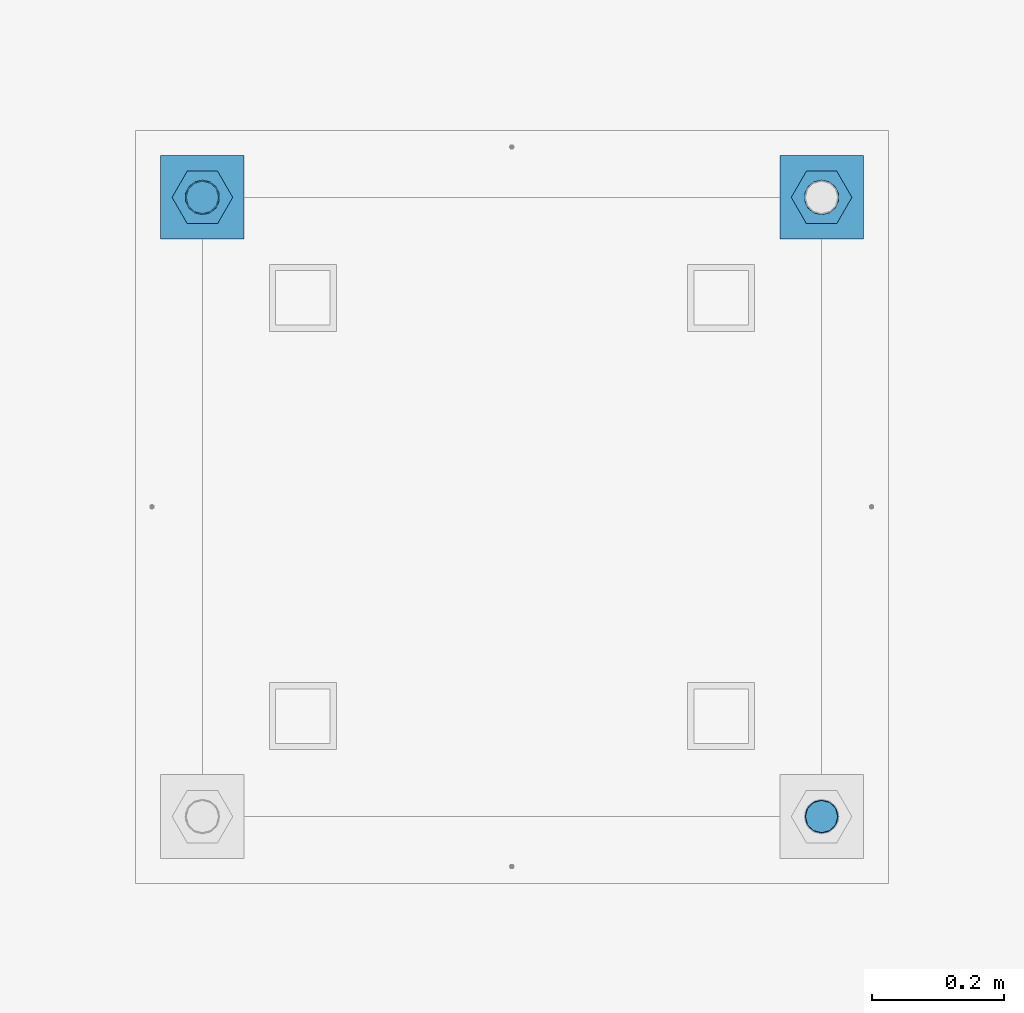
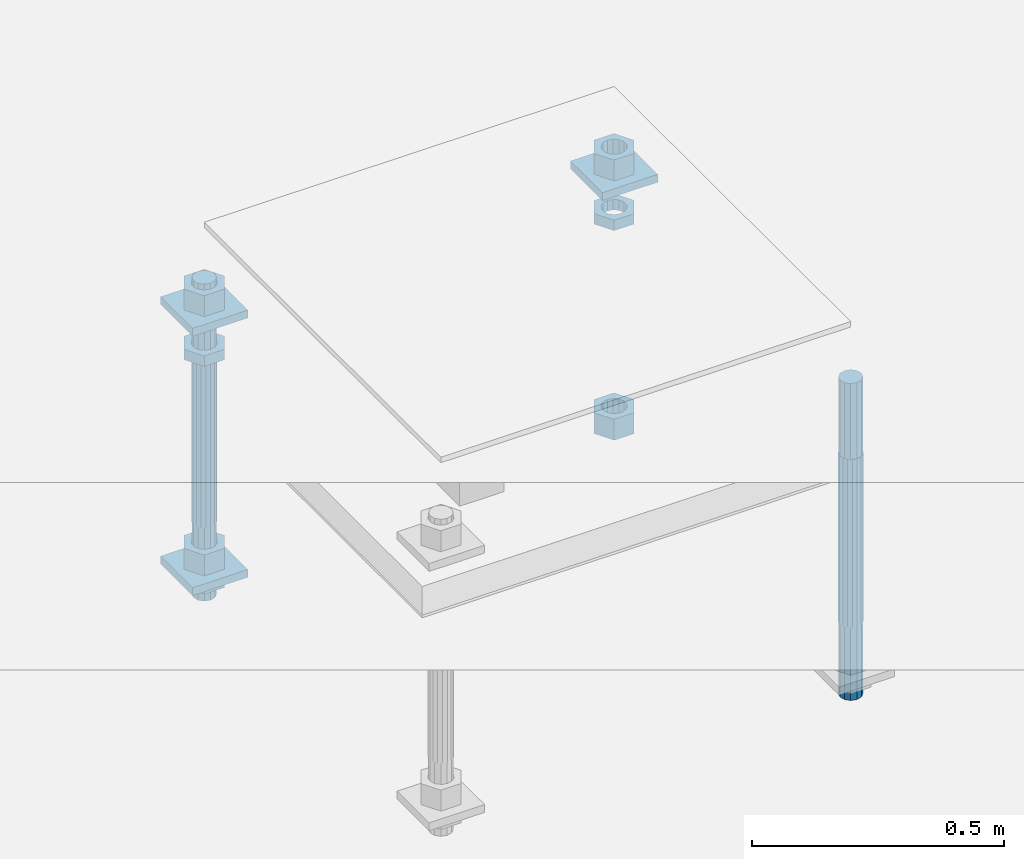
# One storey, part 2578 of 3843: 12 beams, 1 element without a shape of its own.
"""IFC2X3 building model written with IfcOpenShell, lengths in millimetres."""

import ifcopenshell
import ifcopenshell.guid

model = None  # the IFC model being written
_history = None  # IfcOwnerHistory: only IFC2X3 demands one
_inside = {}  # id of a spatial element -> (the spatial element, [elements in it])
_under = {}  # id of a project, library or spatial element -> (it, [spatial elements below it])
_declared = {}  # id of a project -> (the project, [libraries it declares])
_typed = {}  # id of a type object -> (the type object, [elements of that type])
_made_of = {}  # id of a material, layer set ... -> (it, [elements and type objects made of it])


def new_model(schema):
    """Start an empty IFC model of exactly this schema.

    Asked for "IFC4X3", IfcOpenShell would pick the latest addendum, in which some entities
    have other attributes; the version numbers below select the first issue.
    IFC2X3 requires an IfcOwnerHistory on every rooted entity: one is made here for all.
    """
    global model, _history
    if schema == "IFC4X3":
        model = ifcopenshell.file(schema_version=(4, 3, 0, 0))
    else:
        model = ifcopenshell.file(schema=schema)
    _inside.clear()
    _under.clear()
    _declared.clear()
    _typed.clear()
    _made_of.clear()
    _history = None
    if model.schema == "IFC2X3":
        org = make("IfcOrganization", Name="unknown")
        user = make(
            "IfcPersonAndOrganization",
            ThePerson=make("IfcPerson", FamilyName="unknown"),
            TheOrganization=org,
        )
        app = make(
            "IfcApplication",
            ApplicationDeveloper=org,
            Version="unknown",
            ApplicationFullName="unknown",
            ApplicationIdentifier="unknown",
        )
        _history = make(
            "IfcOwnerHistory",
            OwningUser=user,
            OwningApplication=app,
            ChangeAction="ADDED",
            CreationDate=0,
        )
    return model


def make(cls, **values):
    """One entity of the class cls with the attributes given. An attribute that is None is left unset."""
    return model.create_entity(
        cls, **{name: value for name, value in values.items() if value is not None}
    )


def rooted(cls, **values):
    """An entity with a GlobalId (a new one), such as an element, a storey or a relation."""
    return make(cls, GlobalId=ifcopenshell.guid.new(), OwnerHistory=_history, **values)


def si_unit(unit_type, name, prefix=None):
    """IfcSIUnit, for example si_unit("LENGTHUNIT", "METRE", prefix="MILLI")."""
    return make("IfcSIUnit", UnitType=unit_type, Prefix=prefix, Name=name)


def assignment(units):
    """IfcUnitAssignment: the units of a project."""
    return None if units is None else make("IfcUnitAssignment", Units=units)


def point(xyz):
    """IfcCartesianPoint."""
    return None if xyz is None else make("IfcCartesianPoint", Coordinates=xyz)


def direction(xyz):
    """IfcDirection."""
    return None if xyz is None else make("IfcDirection", DirectionRatios=xyz)


def frame(location, z_axis=None, x_axis=None):
    """IfcAxis2Placement3D, a coordinate frame: its origin and axes. An axis left out is left unset."""
    return make(
        "IfcAxis2Placement3D",
        Location=point(location),
        Axis=direction(z_axis),
        RefDirection=direction(x_axis),
    )


def origin_with_axes():
    """The frame at (0, 0, 0) with the z axis (0, 0, 1) and the x axis (1, 0, 0) written out."""
    return frame((0.0, 0.0, 0.0), z_axis=(0.0, 0.0, 1.0), x_axis=(1.0, 0.0, 0.0))


def place(relative_to, where):
    """IfcLocalPlacement: puts the frame where relative to a parent placement (None: the world)."""
    return make(
        "IfcLocalPlacement", PlacementRelTo=relative_to, RelativePlacement=where
    )


def context(
    kind, dimensions, precision=None, world=None, true_north=None, identifier=None
):
    """IfcGeometricRepresentationContext, for example the 3D "Model" context."""
    return make(
        "IfcGeometricRepresentationContext",
        ContextIdentifier=identifier,
        ContextType=kind,
        CoordinateSpaceDimension=dimensions,
        Precision=precision,
        WorldCoordinateSystem=world,
        TrueNorth=true_north,
    )


def subcontext(parent, identifier, kind, view, scale=None):
    """IfcGeometricRepresentationSubContext, for example "Body" below "Model"."""
    return make(
        "IfcGeometricRepresentationSubContext",
        ContextIdentifier=identifier,
        ContextType=kind,
        ParentContext=parent,
        TargetScale=scale,
        TargetView=view,
    )


def project(units=None, contexts=None):
    """IfcProject with its units and contexts."""
    return rooted(
        "IfcProject",
        Name="project",
        RepresentationContexts=contexts,
        UnitsInContext=assignment(units),
    )


def spatial(cls, under=None, at=None, **own):
    """A site, building, storey or space (cls), placed at a placement, below another one or the project."""
    s = rooted(cls, ObjectPlacement=at, **own)
    if under is not None:
        _under.setdefault(under.id(), (under, []))[1].append(s)
    return s


def faces_of(points, faces, orient=None, outer=None):
    """IfcFace entities. A face is a list of loops; a loop is a list of indices into points, from 0.

    orient and outer hold one flag for each loop. By default every Orientation is true, the
    first loop of a face is its IfcFaceOuterBound and the others are IfcFaceBound.
    """
    made = []
    for i, loops in enumerate(faces):
        bounds = []
        for j, loop in enumerate(loops):
            is_outer = j == 0 if outer is None else outer[i][j]
            bounds.append(
                make(
                    "IfcFaceOuterBound" if is_outer else "IfcFaceBound",
                    Bound=make("IfcPolyLoop", Polygon=[points[k] for k in loop]),
                    Orientation=True if orient is None else orient[i][j],
                )
            )
        made.append(make("IfcFace", Bounds=bounds))
    return made


def faceted_brep(points, faces, orient=None, outer=None, voids=None):
    """IfcFacetedBrep: a solid bounded by flat faces; with voids (closed shells), ...WithVoids."""
    shared = [point(p) for p in points]
    hull = make("IfcClosedShell", CfsFaces=faces_of(shared, faces, orient, outer))
    if voids is None:
        return make("IfcFacetedBrep", Outer=hull)
    return make(
        "IfcFacetedBrepWithVoids",
        Outer=hull,
        Voids=[
            make(cls, CfsFaces=faces_of(shared, fs, o, b)) for cls, fs, o, b in voids
        ],
    )


def shape(context_of_items, identifier, shape_type, items):
    """IfcShapeRepresentation: the items that make up one representation, for example the "Body"."""
    return make(
        "IfcShapeRepresentation",
        ContextOfItems=context_of_items,
        RepresentationIdentifier=identifier,
        RepresentationType=shape_type,
        Items=items,
    )


def material(Name=None, Category=None):
    """IfcMaterial."""
    return make("IfcMaterial", Name=Name, Category=Category)


def made_of(thing, what):
    """Note that an element or type object is made of a material, layer set ...; save() writes the relation."""
    if what is not None:
        _made_of.setdefault(what.id(), (what, []))[1].append(thing)
    return thing


def type_object(cls, material=None, **own):
    """A type object (cls), such as IfcWallType, which elements share."""
    return made_of(rooted(cls, **own), material)


def element(
    cls,
    number,
    at=None,
    inside=None,
    cuts=None,
    type_object=None,
    material=None,
    context=None,
    identifier="Body",
    shape_type=None,
    held_by="IfcProductDefinitionShape",
    body=None,
    shapes=None,
    **own,
):
    """One element of the class cls, such as IfcWall. Its Tag is "e" and its number.

    at: its placement. inside: the storey or other place that contains it. cuts: it is an
    opening in that element (IfcRelVoidsElement). A single representation is given by context,
    identifier, shape_type and body (its items); several are given by shapes. held_by: the class
    of the entity that holds the representations. save() writes the other relations.
    """
    e = rooted(cls, Tag="e%d" % number, ObjectPlacement=at, **own)
    if body is not None:
        shapes = [shape(context, identifier, shape_type, body)]
    if shapes is not None:
        e.Representation = make(held_by, Representations=shapes)
    if inside is not None:
        _inside.setdefault(inside.id(), (inside, []))[1].append(e)
    if cuts is not None:
        rooted(
            "IfcRelVoidsElement", RelatingBuildingElement=cuts, RelatedOpeningElement=e
        )
    if type_object is not None:
        _typed.setdefault(type_object.id(), (type_object, []))[1].append(e)
    return made_of(e, material)


def aggregate(whole, parts):
    """IfcRelAggregates: a whole, such as a stair, and the parts it consists of."""
    return rooted("IfcRelAggregates", RelatingObject=whole, RelatedObjects=parts)


def save(model, path):
    """Write the relations noted so far, then the file.

    IfcRelAggregates (storeys below a building ...), IfcRelContainedInSpatialStructure (elements
    in a storey), IfcRelDefinesByType, IfcRelAssociatesMaterial and IfcRelDeclares: one each for
    every whole, place, type object, material and project.
    """
    for whole, parts in _under.values():
        aggregate(whole, parts)
    for where, things in _inside.values():
        rooted(
            "IfcRelContainedInSpatialStructure",
            RelatedElements=things,
            RelatingStructure=where,
        )
    for kind, things in _typed.values():
        rooted("IfcRelDefinesByType", RelatedObjects=things, RelatingType=kind)
    for what, things in _made_of.values():
        rooted("IfcRelAssociatesMaterial", RelatedObjects=things, RelatingMaterial=what)
    for by, libraries in _declared.values():
        rooted("IfcRelDeclares", RelatingContext=by, RelatedDefinitions=libraries)
    model.write(path)


model = new_model("IFC2X3")

# Units and contexts
model_context = context("Model", 3, precision=1e-05, world=origin_with_axes())
body_context = subcontext(model_context, "Body", "Model", "MODEL_VIEW")
ifc_project = project(units=[si_unit("LENGTHUNIT", "METRE", prefix="MILLI"), si_unit("AREAUNIT", "SQUARE_METRE"), si_unit("VOLUMEUNIT", "CUBIC_METRE"), si_unit("MASSUNIT", "GRAM", prefix="KILO"), si_unit("TIMEUNIT", "SECOND"), si_unit("PLANEANGLEUNIT", "RADIAN"), si_unit("SOLIDANGLEUNIT", "STERADIAN"), si_unit("THERMODYNAMICTEMPERATUREUNIT", "DEGREE_CELSIUS"), si_unit("LUMINOUSINTENSITYUNIT", "LUMEN")], contexts=[model_context])

# Site, building, storey
site_placement = place(None, origin_with_axes())
site = spatial("IfcSite", under=ifc_project, at=site_placement, CompositionType="ELEMENT")
building_placement = place(site_placement, origin_with_axes())
building = spatial("IfcBuilding", under=site, at=building_placement, Name="Undefined", CompositionType="ELEMENT")
storey_placement = place(building_placement, origin_with_axes())
storey = spatial("IfcBuildingStorey", under=building, at=storey_placement, Name="Undefined", CompositionType="ELEMENT", Elevation=0.0)

# Assembly, beams
assembly_placement = place(storey_placement, origin_with_axes())
assembly = element("IfcElementAssembly", 1, at=assembly_placement, inside=storey, Name="TEMPLATE", AssemblyPlace="NOTDEFINED", PredefinedType="RIGID_FRAME")
ifc_material_1 = material(Name="STEEL/A36")
beam_type_1 = type_object("IfcBeamType", PredefinedType="NOTDEFINED")
beam_1_placement = place(assembly_placement, frame((108483.4, 10909.3000015259, 29873.575), z_axis=(1.0, 0.0, 0.0), x_axis=(0.0, 1.0, 0.0)))
beam_1 = element("IfcBeam", 2, at=beam_1_placement, type_object=beam_type_1, material=ifc_material_1, Name="WASHER_PLATE", context=body_context, shape_type="Brep", body=[
    faceted_brep([(0.0, 9.52500000000146, -63.5), (0.0, 9.52500000000146, 63.5), (127.0, 9.52500000000146, 63.5), (127.0, 9.52500000000146, -63.5), (0.0, -9.52500000000146, 63.5), (127.0, -9.52500000000146, 63.5), (0.0, -9.52500000000146, -63.5), (127.0, -9.52500000000146, -63.5)], [[[0, 1, 2, 3]], [[1, 4, 5, 2]], [[4, 6, 7, 5]], [[6, 0, 3, 7]], [[5, 7, 3, 2]], [[6, 4, 1, 0]]]),
])
beam_2_placement = place(assembly_placement, frame((109423.2, 10909.3000015259, 29873.575), z_axis=(1.0, 0.0, 0.0), x_axis=(0.0, 1.0, 0.0)))
beam_2 = element("IfcBeam", 3, at=beam_2_placement, type_object=beam_type_1, material=ifc_material_1, Name="WASHER_PLATE", context=body_context, shape_type="Brep", body=[
    faceted_brep([(0.0, 9.52500000000146, -63.5), (0.0, 9.52500000000146, 63.5), (127.0, 9.52500000000146, 63.5), (127.0, 9.52500000000146, -63.5), (0.0, -9.52500000000146, 63.5), (127.0, -9.52500000000146, 63.5), (0.0, -9.52500000000146, -63.5), (127.0, -9.52500000000146, -63.5)], [[[0, 1, 2, 3]], [[1, 4, 5, 2]], [[4, 6, 7, 5]], [[6, 0, 3, 7]], [[5, 7, 3, 2]], [[6, 4, 1, 0]]]),
])
beam_3_placement = place(assembly_placement, frame((108483.4, 10909.3000015259, 29244.925), z_axis=(1.0, 0.0, 0.0), x_axis=(0.0, 1.0, 0.0)))
beam_3 = element("IfcBeam", 4, at=beam_3_placement, type_object=beam_type_1, material=ifc_material_1, Name="WASHER_PLATE", context=body_context, shape_type="Brep", body=[
    faceted_brep([(0.0, 9.52500000000146, -63.5), (0.0, 9.52500000000146, 63.5), (127.0, 9.52500000000146, 63.5), (127.0, 9.52500000000146, -63.5), (0.0, -9.52500000000146, 63.5), (127.0, -9.52500000000146, 63.5), (0.0, -9.52500000000146, -63.5), (127.0, -9.52500000000146, -63.5)], [[[0, 1, 2, 3]], [[1, 4, 5, 2]], [[4, 6, 7, 5]], [[6, 0, 3, 7]], [[5, 7, 3, 2]], [[6, 4, 1, 0]]]),
])
beam_type_2 = type_object("IfcBeamType", Name="2_HALF_NUT", PredefinedType="NOTDEFINED")
beam_4_placement = place(assembly_placement, frame((108483.4, 10972.8000015259, 29787.85), z_axis=(0.0, -1.0, 0.0), x_axis=(0.0, 0.0, -1.0)))
beam_4 = element("IfcBeam", 5, at=beam_4_placement, type_object=beam_type_2, material=ifc_material_1, Name="NUT", ObjectType="2_HALF_NUT", context=body_context, shape_type="Brep", body=[
    faceted_brep([(0.0, -46.0369987487793, 0.0), (0.0, -23.0184993743896, -39.869213104248), (25.4000000000015, -23.0184993743896, -39.869213104248), (25.4000000000015, -46.0369987487793, 0.0), (0.0, 23.0184993743896, -39.869213104248), (25.4000000000015, 23.0184993743896, -39.869213104248), (0.0, 46.0369987487793, 0.0), (25.4000000000015, 46.0369987487793, 0.0), (0.0, 23.0184993743896, 39.869213104248), (25.4000000000015, 23.0184993743896, 39.869213104248), (0.0, -23.0184993743896, 39.869213104248), (25.4000000000015, -23.0184993743896, 39.869213104248), (0.0, 0.0, 26.1940002441406), (0.0, 11.3650617044477, 23.5999013092805), (25.4000000000015, 11.3650617044477, 23.5999013092805), (25.4000000000015, 0.0, 26.1940002441406), (0.0, 20.4791109456419, 16.3316083006721), (25.4000000000015, 20.4791109456419, 16.3316083006721), (0.0, 25.5370200498292, 5.82867859874386), (25.4000000000015, 25.5370200498292, 5.82867859874386), (0.0, 25.5370200498292, -5.82867859874386), (25.4000000000015, 25.5370200498292, -5.82867859874386), (0.0, 20.4791109456419, -16.3316083006721), (25.4000000000015, 20.4791109456419, -16.3316083006721), (0.0, 11.3650617044477, -23.5999013092805), (25.4000000000015, 11.3650617044477, -23.5999013092805), (0.0, 0.0, -26.1940002441406), (25.4000000000015, 0.0, -26.1940002441406), (0.0, -11.3650617044477, -23.5999013092805), (25.4000000000015, -11.3650617044477, -23.5999013092805), (0.0, -20.4791109456419, -16.3316083006721), (25.4000000000015, -20.4791109456419, -16.3316083006721), (0.0, -25.5370200498292, -5.82867859874386), (25.4000000000015, -25.5370200498292, -5.82867859874386), (0.0, -25.5370200498292, 5.82867859874386), (25.4000000000015, -25.5370200498292, 5.82867859874386), (0.0, -20.4791109456419, 16.3316083006721), (25.4000000000015, -20.4791109456419, 16.3316083006721), (0.0, -11.3650617044477, 23.5999013092805), (25.4000000000015, -11.3650617044477, 23.5999013092805)], [[[0, 1, 2, 3]], [[1, 4, 5, 2]], [[4, 6, 7, 5]], [[6, 8, 9, 7]], [[8, 10, 11, 9]], [[10, 0, 3, 11]], [[12, 13, 14, 15]], [[13, 16, 17, 14]], [[16, 18, 19, 17]], [[18, 20, 21, 19]], [[20, 22, 23, 21]], [[22, 24, 25, 23]], [[24, 26, 27, 25]], [[26, 28, 29, 27]], [[28, 30, 31, 29]], [[30, 32, 33, 31]], [[32, 34, 35, 33]], [[34, 36, 37, 35]], [[36, 38, 39, 37]], [[38, 12, 15, 39]], [[5, 7, 9, 11, 3, 2], [17, 19, 21, 23, 25, 27, 29, 31, 33, 35, 37, 39, 15, 14]], [[10, 8, 6, 4, 1, 0], [38, 36, 34, 32, 30, 28, 26, 24, 22, 20, 18, 16, 13, 12]]]),
])
beam_5_placement = place(assembly_placement, frame((109423.2, 10972.8000015259, 29787.85), z_axis=(0.0, 1.0, 0.0), x_axis=(0.0, 0.0, -1.0)))
beam_5 = element("IfcBeam", 6, at=beam_5_placement, type_object=beam_type_2, material=ifc_material_1, Name="NUT", ObjectType="2_HALF_NUT", context=body_context, shape_type="Brep", body=[
    faceted_brep([(0.0, -46.0369987487793, 0.0), (0.0, -23.0184993743896, -39.869213104248), (25.4000000000015, -23.0184993743896, -39.869213104248), (25.4000000000015, -46.0369987487793, 0.0), (0.0, 23.0184993743896, -39.869213104248), (25.4000000000015, 23.0184993743896, -39.869213104248), (0.0, 46.0369987487793, 0.0), (25.4000000000015, 46.0369987487793, 0.0), (0.0, 23.0184993743896, 39.869213104248), (25.4000000000015, 23.0184993743896, 39.869213104248), (0.0, -23.0184993743896, 39.869213104248), (25.4000000000015, -23.0184993743896, 39.869213104248), (0.0, 0.0, 26.1940002441406), (0.0, 11.3650617044477, 23.5999013092805), (25.4000000000015, 11.3650617044477, 23.5999013092805), (25.4000000000015, 0.0, 26.1940002441406), (0.0, 20.4791109456419, 16.3316083006721), (25.4000000000015, 20.4791109456419, 16.3316083006721), (0.0, 25.5370200498292, 5.82867859874386), (25.4000000000015, 25.5370200498292, 5.82867859874386), (0.0, 25.5370200498292, -5.82867859874386), (25.4000000000015, 25.5370200498292, -5.82867859874386), (0.0, 20.4791109456419, -16.3316083006721), (25.4000000000015, 20.4791109456419, -16.3316083006721), (0.0, 11.3650617044477, -23.5999013092805), (25.4000000000015, 11.3650617044477, -23.5999013092805), (0.0, 0.0, -26.1940002441406), (25.4000000000015, 0.0, -26.1940002441406), (0.0, -11.3650617044477, -23.5999013092805), (25.4000000000015, -11.3650617044477, -23.5999013092805), (0.0, -20.4791109456419, -16.3316083006721), (25.4000000000015, -20.4791109456419, -16.3316083006721), (0.0, -25.5370200498292, -5.82867859874386), (25.4000000000015, -25.5370200498292, -5.82867859874386), (0.0, -25.5370200498292, 5.82867859874386), (25.4000000000015, -25.5370200498292, 5.82867859874386), (0.0, -20.4791109456419, 16.3316083006721), (25.4000000000015, -20.4791109456419, 16.3316083006721), (0.0, -11.3650617044477, 23.5999013092805), (25.4000000000015, -11.3650617044477, 23.5999013092805)], [[[0, 1, 2, 3]], [[1, 4, 5, 2]], [[4, 6, 7, 5]], [[6, 8, 9, 7]], [[8, 10, 11, 9]], [[10, 0, 3, 11]], [[12, 13, 14, 15]], [[13, 16, 17, 14]], [[16, 18, 19, 17]], [[18, 20, 21, 19]], [[20, 22, 23, 21]], [[22, 24, 25, 23]], [[24, 26, 27, 25]], [[26, 28, 29, 27]], [[28, 30, 31, 29]], [[30, 32, 33, 31]], [[32, 34, 35, 33]], [[34, 36, 37, 35]], [[36, 38, 39, 37]], [[38, 12, 15, 39]], [[5, 7, 9, 11, 3, 2], [17, 19, 21, 23, 25, 27, 29, 31, 33, 35, 37, 39, 15, 14]], [[10, 8, 6, 4, 1, 0], [38, 36, 34, 32, 30, 28, 26, 24, 22, 20, 18, 16, 13, 12]]]),
])
beam_6_placement = place(assembly_placement, frame((108483.4, 10972.8000015259, 29235.4), z_axis=(0.0, -1.0, 0.0), x_axis=(0.0, 0.0, -1.0)))
beam_6 = element("IfcBeam", 7, at=beam_6_placement, type_object=beam_type_2, material=ifc_material_1, Name="NUT", ObjectType="2_HALF_NUT", context=body_context, shape_type="Brep", body=[
    faceted_brep([(0.0, -46.0369987487793, 0.0), (0.0, -23.0184993743896, -39.869213104248), (25.4000000000015, -23.0184993743896, -39.869213104248), (25.4000000000015, -46.0369987487793, 0.0), (0.0, 23.0184993743896, -39.869213104248), (25.4000000000015, 23.0184993743896, -39.869213104248), (0.0, 46.0369987487793, 0.0), (25.4000000000015, 46.0369987487793, 0.0), (0.0, 23.0184993743896, 39.869213104248), (25.4000000000015, 23.0184993743896, 39.869213104248), (0.0, -23.0184993743896, 39.869213104248), (25.4000000000015, -23.0184993743896, 39.869213104248), (0.0, 0.0, 26.1940002441406), (0.0, 11.3650617044477, 23.5999013092805), (25.4000000000015, 11.3650617044477, 23.5999013092805), (25.4000000000015, 0.0, 26.1940002441406), (0.0, 20.4791109456419, 16.3316083006721), (25.4000000000015, 20.4791109456419, 16.3316083006721), (0.0, 25.5370200498292, 5.82867859874386), (25.4000000000015, 25.5370200498292, 5.82867859874386), (0.0, 25.5370200498292, -5.82867859874386), (25.4000000000015, 25.5370200498292, -5.82867859874386), (0.0, 20.4791109456419, -16.3316083006721), (25.4000000000015, 20.4791109456419, -16.3316083006721), (0.0, 11.3650617044477, -23.5999013092805), (25.4000000000015, 11.3650617044477, -23.5999013092805), (0.0, 0.0, -26.1940002441406), (25.4000000000015, 0.0, -26.1940002441406), (0.0, -11.3650617044477, -23.5999013092805), (25.4000000000015, -11.3650617044477, -23.5999013092805), (0.0, -20.4791109456419, -16.3316083006721), (25.4000000000015, -20.4791109456419, -16.3316083006721), (0.0, -25.5370200498292, -5.82867859874386), (25.4000000000015, -25.5370200498292, -5.82867859874386), (0.0, -25.5370200498292, 5.82867859874386), (25.4000000000015, -25.5370200498292, 5.82867859874386), (0.0, -20.4791109456419, 16.3316083006721), (25.4000000000015, -20.4791109456419, 16.3316083006721), (0.0, -11.3650617044477, 23.5999013092805), (25.4000000000015, -11.3650617044477, 23.5999013092805)], [[[0, 1, 2, 3]], [[1, 4, 5, 2]], [[4, 6, 7, 5]], [[6, 8, 9, 7]], [[8, 10, 11, 9]], [[10, 0, 3, 11]], [[12, 13, 14, 15]], [[13, 16, 17, 14]], [[16, 18, 19, 17]], [[18, 20, 21, 19]], [[20, 22, 23, 21]], [[22, 24, 25, 23]], [[24, 26, 27, 25]], [[26, 28, 29, 27]], [[28, 30, 31, 29]], [[30, 32, 33, 31]], [[32, 34, 35, 33]], [[34, 36, 37, 35]], [[36, 38, 39, 37]], [[38, 12, 15, 39]], [[5, 7, 9, 11, 3, 2], [17, 19, 21, 23, 25, 27, 29, 31, 33, 35, 37, 39, 15, 14]], [[10, 8, 6, 4, 1, 0], [38, 36, 34, 32, 30, 28, 26, 24, 22, 20, 18, 16, 13, 12]]]),
])
beam_type_3 = type_object("IfcBeamType", Name="2_HEAVY_HEX_NUT", PredefinedType="NOTDEFINED")
beam_7_placement = place(assembly_placement, frame((108483.4, 10972.8000015259, 29933.9), z_axis=(0.0, -1.0, 0.0), x_axis=(0.0, 0.0, -1.0)))
beam_7 = element("IfcBeam", 8, at=beam_7_placement, type_object=beam_type_3, material=ifc_material_1, Name="NUT", ObjectType="2_HEAVY_HEX_NUT", context=body_context, shape_type="Brep", body=[
    faceted_brep([(0.0, -46.0369987487793, 0.0), (0.0, -23.0184993743896, -39.869213104248), (50.7999999999993, -23.0184993743896, -39.869213104248), (50.7999999999993, -46.0369987487793, 0.0), (0.0, 23.0184993743896, -39.869213104248), (50.7999999999993, 23.0184993743896, -39.869213104248), (0.0, 46.0369987487793, 0.0), (50.7999999999993, 46.0369987487793, 0.0), (0.0, 23.0184993743896, 39.869213104248), (50.7999999999993, 23.0184993743896, 39.869213104248), (0.0, -23.0184993743896, 39.869213104248), (50.7999999999993, -23.0184993743896, 39.869213104248), (0.0, 0.0, 26.1940002441406), (0.0, 11.3650617044477, 23.5999013092805), (50.7999999999993, 11.3650617044477, 23.5999013092805), (50.7999999999993, 0.0, 26.1940002441406), (0.0, 20.4791109456419, 16.3316083006721), (50.7999999999993, 20.4791109456419, 16.3316083006721), (0.0, 25.5370200498292, 5.82867859874386), (50.7999999999993, 25.5370200498292, 5.82867859874386), (0.0, 25.5370200498292, -5.82867859874386), (50.7999999999993, 25.5370200498292, -5.82867859874386), (0.0, 20.4791109456419, -16.3316083006721), (50.7999999999993, 20.4791109456419, -16.3316083006721), (0.0, 11.3650617044477, -23.5999013092805), (50.7999999999993, 11.3650617044477, -23.5999013092805), (0.0, 0.0, -26.1940002441406), (50.7999999999993, 0.0, -26.1940002441406), (0.0, -11.3650617044477, -23.5999013092805), (50.7999999999993, -11.3650617044477, -23.5999013092805), (0.0, -20.4791109456419, -16.3316083006721), (50.7999999999993, -20.4791109456419, -16.3316083006721), (0.0, -25.5370200498292, -5.82867859874386), (50.7999999999993, -25.5370200498292, -5.82867859874386), (0.0, -25.5370200498292, 5.82867859874386), (50.7999999999993, -25.5370200498292, 5.82867859874386), (0.0, -20.4791109456419, 16.3316083006721), (50.7999999999993, -20.4791109456419, 16.3316083006721), (0.0, -11.3650617044477, 23.5999013092805), (50.7999999999993, -11.3650617044477, 23.5999013092805)], [[[0, 1, 2, 3]], [[1, 4, 5, 2]], [[4, 6, 7, 5]], [[6, 8, 9, 7]], [[8, 10, 11, 9]], [[10, 0, 3, 11]], [[12, 13, 14, 15]], [[13, 16, 17, 14]], [[16, 18, 19, 17]], [[18, 20, 21, 19]], [[20, 22, 23, 21]], [[22, 24, 25, 23]], [[24, 26, 27, 25]], [[26, 28, 29, 27]], [[28, 30, 31, 29]], [[30, 32, 33, 31]], [[32, 34, 35, 33]], [[34, 36, 37, 35]], [[36, 38, 39, 37]], [[38, 12, 15, 39]], [[5, 7, 9, 11, 3, 2], [17, 19, 21, 23, 25, 27, 29, 31, 33, 35, 37, 39, 15, 14]], [[10, 8, 6, 4, 1, 0], [38, 36, 34, 32, 30, 28, 26, 24, 22, 20, 18, 16, 13, 12]]]),
])
beam_8_placement = place(assembly_placement, frame((108483.4, 10972.8000015259, 29305.25), z_axis=(0.0, -1.0, 0.0), x_axis=(0.0, 0.0, -1.0)))
beam_8 = element("IfcBeam", 9, at=beam_8_placement, type_object=beam_type_3, material=ifc_material_1, Name="NUT", ObjectType="2_HEAVY_HEX_NUT", context=body_context, shape_type="Brep", body=[
    faceted_brep([(0.0, -46.0369987487793, 0.0), (0.0, -23.0184993743896, -39.869213104248), (50.7999999999993, -23.0184993743896, -39.869213104248), (50.7999999999993, -46.0369987487793, 0.0), (0.0, 23.0184993743896, -39.869213104248), (50.7999999999993, 23.0184993743896, -39.869213104248), (0.0, 46.0369987487793, 0.0), (50.7999999999993, 46.0369987487793, 0.0), (0.0, 23.0184993743896, 39.869213104248), (50.7999999999993, 23.0184993743896, 39.869213104248), (0.0, -23.0184993743896, 39.869213104248), (50.7999999999993, -23.0184993743896, 39.869213104248), (0.0, 0.0, 26.1940002441406), (0.0, 11.3650617044477, 23.5999013092805), (50.7999999999993, 11.3650617044477, 23.5999013092805), (50.7999999999993, 0.0, 26.1940002441406), (0.0, 20.4791109456419, 16.3316083006721), (50.7999999999993, 20.4791109456419, 16.3316083006721), (0.0, 25.5370200498292, 5.82867859874386), (50.7999999999993, 25.5370200498292, 5.82867859874386), (0.0, 25.5370200498292, -5.82867859874386), (50.7999999999993, 25.5370200498292, -5.82867859874386), (0.0, 20.4791109456419, -16.3316083006721), (50.7999999999993, 20.4791109456419, -16.3316083006721), (0.0, 11.3650617044477, -23.5999013092805), (50.7999999999993, 11.3650617044477, -23.5999013092805), (0.0, 0.0, -26.1940002441406), (50.7999999999993, 0.0, -26.1940002441406), (0.0, -11.3650617044477, -23.5999013092805), (50.7999999999993, -11.3650617044477, -23.5999013092805), (0.0, -20.4791109456419, -16.3316083006721), (50.7999999999993, -20.4791109456419, -16.3316083006721), (0.0, -25.5370200498292, -5.82867859874386), (50.7999999999993, -25.5370200498292, -5.82867859874386), (0.0, -25.5370200498292, 5.82867859874386), (50.7999999999993, -25.5370200498292, 5.82867859874386), (0.0, -20.4791109456419, 16.3316083006721), (50.7999999999993, -20.4791109456419, 16.3316083006721), (0.0, -11.3650617044477, 23.5999013092805), (50.7999999999993, -11.3650617044477, 23.5999013092805)], [[[0, 1, 2, 3]], [[1, 4, 5, 2]], [[4, 6, 7, 5]], [[6, 8, 9, 7]], [[8, 10, 11, 9]], [[10, 0, 3, 11]], [[12, 13, 14, 15]], [[13, 16, 17, 14]], [[16, 18, 19, 17]], [[18, 20, 21, 19]], [[20, 22, 23, 21]], [[22, 24, 25, 23]], [[24, 26, 27, 25]], [[26, 28, 29, 27]], [[28, 30, 31, 29]], [[30, 32, 33, 31]], [[32, 34, 35, 33]], [[34, 36, 37, 35]], [[36, 38, 39, 37]], [[38, 12, 15, 39]], [[5, 7, 9, 11, 3, 2], [17, 19, 21, 23, 25, 27, 29, 31, 33, 35, 37, 39, 15, 14]], [[10, 8, 6, 4, 1, 0], [38, 36, 34, 32, 30, 28, 26, 24, 22, 20, 18, 16, 13, 12]]]),
])
beam_9_placement = place(assembly_placement, frame((109423.2, 10972.8000015259, 29933.9), z_axis=(0.0, 1.0, 0.0), x_axis=(0.0, 0.0, -1.0)))
beam_9 = element("IfcBeam", 10, at=beam_9_placement, type_object=beam_type_3, material=ifc_material_1, Name="NUT", ObjectType="2_HEAVY_HEX_NUT", context=body_context, shape_type="Brep", body=[
    faceted_brep([(0.0, -46.0369987487793, 0.0), (0.0, -23.0184993743896, -39.869213104248), (50.7999999999993, -23.0184993743896, -39.869213104248), (50.7999999999993, -46.0369987487793, 0.0), (0.0, 23.0184993743896, -39.869213104248), (50.7999999999993, 23.0184993743896, -39.869213104248), (0.0, 46.0369987487793, 0.0), (50.7999999999993, 46.0369987487793, 0.0), (0.0, 23.0184993743896, 39.869213104248), (50.7999999999993, 23.0184993743896, 39.869213104248), (0.0, -23.0184993743896, 39.869213104248), (50.7999999999993, -23.0184993743896, 39.869213104248), (0.0, 0.0, 26.1940002441406), (0.0, 11.3650617044477, 23.5999013092805), (50.7999999999993, 11.3650617044477, 23.5999013092805), (50.7999999999993, 0.0, 26.1940002441406), (0.0, 20.4791109456419, 16.3316083006721), (50.7999999999993, 20.4791109456419, 16.3316083006721), (0.0, 25.5370200498292, 5.82867859874386), (50.7999999999993, 25.5370200498292, 5.82867859874386), (0.0, 25.5370200498292, -5.82867859874386), (50.7999999999993, 25.5370200498292, -5.82867859874386), (0.0, 20.4791109456419, -16.3316083006721), (50.7999999999993, 20.4791109456419, -16.3316083006721), (0.0, 11.3650617044477, -23.5999013092805), (50.7999999999993, 11.3650617044477, -23.5999013092805), (0.0, 0.0, -26.1940002441406), (50.7999999999993, 0.0, -26.1940002441406), (0.0, -11.3650617044477, -23.5999013092805), (50.7999999999993, -11.3650617044477, -23.5999013092805), (0.0, -20.4791109456419, -16.3316083006721), (50.7999999999993, -20.4791109456419, -16.3316083006721), (0.0, -25.5370200498292, -5.82867859874386), (50.7999999999993, -25.5370200498292, -5.82867859874386), (0.0, -25.5370200498292, 5.82867859874386), (50.7999999999993, -25.5370200498292, 5.82867859874386), (0.0, -20.4791109456419, 16.3316083006721), (50.7999999999993, -20.4791109456419, 16.3316083006721), (0.0, -11.3650617044477, 23.5999013092805), (50.7999999999993, -11.3650617044477, 23.5999013092805)], [[[0, 1, 2, 3]], [[1, 4, 5, 2]], [[4, 6, 7, 5]], [[6, 8, 9, 7]], [[8, 10, 11, 9]], [[10, 0, 3, 11]], [[12, 13, 14, 15]], [[13, 16, 17, 14]], [[16, 18, 19, 17]], [[18, 20, 21, 19]], [[20, 22, 23, 21]], [[22, 24, 25, 23]], [[24, 26, 27, 25]], [[26, 28, 29, 27]], [[28, 30, 31, 29]], [[30, 32, 33, 31]], [[32, 34, 35, 33]], [[34, 36, 37, 35]], [[36, 38, 39, 37]], [[38, 12, 15, 39]], [[5, 7, 9, 11, 3, 2], [17, 19, 21, 23, 25, 27, 29, 31, 33, 35, 37, 39, 15, 14]], [[10, 8, 6, 4, 1, 0], [38, 36, 34, 32, 30, 28, 26, 24, 22, 20, 18, 16, 13, 12]]]),
])
beam_10_placement = place(assembly_placement, frame((109423.2, 10972.8000015259, 29305.25), z_axis=(0.0, 1.0, 0.0), x_axis=(0.0, 0.0, -1.0)))
beam_10 = element("IfcBeam", 11, at=beam_10_placement, type_object=beam_type_3, material=ifc_material_1, Name="NUT", ObjectType="2_HEAVY_HEX_NUT", context=body_context, shape_type="Brep", body=[
    faceted_brep([(0.0, -46.0369987487793, 0.0), (0.0, -23.0184993743896, -39.869213104248), (50.7999999999993, -23.0184993743896, -39.869213104248), (50.7999999999993, -46.0369987487793, 0.0), (0.0, 23.0184993743896, -39.869213104248), (50.7999999999993, 23.0184993743896, -39.869213104248), (0.0, 46.0369987487793, 0.0), (50.7999999999993, 46.0369987487793, 0.0), (0.0, 23.0184993743896, 39.869213104248), (50.7999999999993, 23.0184993743896, 39.869213104248), (0.0, -23.0184993743896, 39.869213104248), (50.7999999999993, -23.0184993743896, 39.869213104248), (0.0, 0.0, 26.1940002441406), (0.0, 11.3650617044477, 23.5999013092805), (50.7999999999993, 11.3650617044477, 23.5999013092805), (50.7999999999993, 0.0, 26.1940002441406), (0.0, 20.4791109456419, 16.3316083006721), (50.7999999999993, 20.4791109456419, 16.3316083006721), (0.0, 25.5370200498292, 5.82867859874386), (50.7999999999993, 25.5370200498292, 5.82867859874386), (0.0, 25.5370200498292, -5.82867859874386), (50.7999999999993, 25.5370200498292, -5.82867859874386), (0.0, 20.4791109456419, -16.3316083006721), (50.7999999999993, 20.4791109456419, -16.3316083006721), (0.0, 11.3650617044477, -23.5999013092805), (50.7999999999993, 11.3650617044477, -23.5999013092805), (0.0, 0.0, -26.1940002441406), (50.7999999999993, 0.0, -26.1940002441406), (0.0, -11.3650617044477, -23.5999013092805), (50.7999999999993, -11.3650617044477, -23.5999013092805), (0.0, -20.4791109456419, -16.3316083006721), (50.7999999999993, -20.4791109456419, -16.3316083006721), (0.0, -25.5370200498292, -5.82867859874386), (50.7999999999993, -25.5370200498292, -5.82867859874386), (0.0, -25.5370200498292, 5.82867859874386), (50.7999999999993, -25.5370200498292, 5.82867859874386), (0.0, -20.4791109456419, 16.3316083006721), (50.7999999999993, -20.4791109456419, 16.3316083006721), (0.0, -11.3650617044477, 23.5999013092805), (50.7999999999993, -11.3650617044477, 23.5999013092805)], [[[0, 1, 2, 3]], [[1, 4, 5, 2]], [[4, 6, 7, 5]], [[6, 8, 9, 7]], [[8, 10, 11, 9]], [[10, 0, 3, 11]], [[12, 13, 14, 15]], [[13, 16, 17, 14]], [[16, 18, 19, 17]], [[18, 20, 21, 19]], [[20, 22, 23, 21]], [[22, 24, 25, 23]], [[24, 26, 27, 25]], [[26, 28, 29, 27]], [[28, 30, 31, 29]], [[30, 32, 33, 31]], [[32, 34, 35, 33]], [[34, 36, 37, 35]], [[36, 38, 39, 37]], [[38, 12, 15, 39]], [[5, 7, 9, 11, 3, 2], [17, 19, 21, 23, 25, 27, 29, 31, 33, 35, 37, 39, 15, 14]], [[10, 8, 6, 4, 1, 0], [38, 36, 34, 32, 30, 28, 26, 24, 22, 20, 18, 16, 13, 12]]]),
])
ifc_material_2 = material()
beam_type_4 = type_object("IfcBeamType", PredefinedType="NOTDEFINED")
beam_11_placement = place(assembly_placement, frame((109423.2, 10033.0000015259, 29762.45), z_axis=(0.0, 1.0, 0.0), x_axis=(0.0, 0.0, -1.0)))
beam_11 = element("IfcBeam", 12, at=beam_11_placement, type_object=beam_type_4, material=ifc_material_2, Name="ANCHOR_ROD", context=body_context, shape_type="Brep", body=[
    faceted_brep([(-184.150000000001, -21.217622392709, 12.25), (-184.150000000001, -12.2499999999854, 21.2176223927163), (-184.150000000001, 1.45519152283669e-11, 24.5), (-184.150000000001, 12.2500000000146, 21.2176223927163), (-184.150000000001, 21.2176223927381, 12.25), (-184.150000000001, 24.5000000000146, 0.0), (-184.150000000001, 21.2176223927381, -12.25), (-184.150000000001, 12.2500000000146, -21.2176223927163), (-184.150000000001, 1.45519152283669e-11, -24.5), (-184.150000000001, -12.2499999999854, -21.2176223927163), (-184.150000000001, -21.217622392709, -12.25), (-184.150000000001, -24.4999999999854, 0.0), (0.0, 24.5000000000146, 0.0), (0.0, 21.2176223927381, -12.25), (0.0, 12.2500000000146, -21.2176223927163), (0.0, 1.45519152283669e-11, -24.5), (0.0, -12.2499999999854, -21.2176223927163), (0.0, -21.217622392709, -12.25), (0.0, -24.4999999999854, 0.0), (0.0, -21.217622392709, 12.25), (0.0, -12.2499999999854, 21.2176223927163), (0.0, 1.45519152283669e-11, 24.5), (0.0, 12.2500000000146, 21.2176223927163), (0.0, 21.2176223927381, 12.25), (0.0, -23.4665401257807, 9.72015918207035), (0.0, -17.9605122421344, 17.9605122421417), (0.0, -9.72015918207762, 23.466540125788), (0.0, 0.0, 25.4000000000015), (0.0, 9.72015918207762, 23.466540125788), (0.0, 17.9605122421344, 17.9605122421417), (0.0, 23.4665401257807, 9.72015918207035), (0.0, 25.3999996185303, 0.0), (0.0, 23.4665401257807, -9.72015918207035), (0.0, 17.9605122421344, -17.9605122421417), (0.0, 9.72015918207762, -23.466540125788), (0.0, 0.0, -25.4000000000015), (0.0, -9.72015918207762, -23.466540125788), (0.0, -17.9605122421344, -17.9605122421417), (0.0, -23.4665401257807, -9.72015918207035), (0.0, -25.3999996185303, 0.0), (406.399999999998, -25.3999999999942, 0.0), (406.399999999998, -23.4665401257807, 9.72015918207035), (406.399999999998, -17.9605122421344, 17.9605122421417), (406.399999999998, -9.72015918207762, 23.466540125788), (406.399999999998, 0.0, 25.4000000000015), (406.399999999998, 9.72015918207762, 23.466540125788), (406.399999999998, 17.9605122421344, 17.9605122421417), (406.399999999998, 23.4665401257807, 9.72015918207035), (406.399999999998, 25.3999999999942, 0.0), (406.399999999998, 23.4665401257807, -9.72015918207035), (406.399999999998, 17.9605122421344, -17.9605122421417), (406.399999999998, 9.72015918207762, -23.466540125788), (406.399999999998, 0.0, -25.4000000000015), (406.399999999998, -9.72015918207762, -23.466540125788), (406.399999999998, -17.9605122421344, -17.9605122421417), (406.399999999998, -23.4665401257807, -9.72015918207035), (406.399999999998, -12.2499999999854, 21.2176223927163), (406.399999999998, 1.45519152283669e-11, 24.5), (406.399999999998, 12.2500000000146, 21.2176223927163), (406.399999999998, 21.2176223927381, 12.25), (406.399999999998, 24.5000000000146, 0.0), (406.399999999998, 21.2176223927381, -12.25), (406.399999999998, 12.2500000000146, -21.2176223927163), (406.399999999998, 1.45519152283669e-11, -24.5), (406.399999999998, -12.2499999999854, -21.2176223927163), (406.399999999998, -21.217622392709, -12.25), (406.399999999998, -24.4999999999854, 0.0), (406.399999999998, -21.217622392709, 12.25), (584.200000000001, -12.2499999999854, -21.2176223927163), (584.200000000001, 1.45519152283669e-11, -24.5), (584.200000000001, 12.2500000000146, -21.2176223927163), (584.200000000001, 21.2176223927381, -12.25), (584.200000000001, 24.5000000000146, 0.0), (584.200000000001, 21.2176223927381, 12.25), (584.200000000001, 12.2500000000146, 21.2176223927163), (584.200000000001, 1.45519152283669e-11, 24.5), (584.200000000001, -12.2499999999854, 21.2176223927163), (584.200000000001, -21.217622392709, 12.25), (584.200000000001, -24.4999999999854, 0.0), (584.200000000001, -21.217622392709, -12.25)], [[[0, 1, 2, 3, 4, 5, 6, 7, 8, 9, 10, 11]], [[6, 5, 12, 13]], [[7, 6, 13, 14]], [[8, 7, 14, 15]], [[9, 8, 15, 16]], [[10, 9, 16, 17]], [[11, 10, 17, 18]], [[0, 11, 18, 19]], [[1, 0, 19, 20]], [[2, 1, 20, 21]], [[3, 2, 21, 22]], [[4, 3, 22, 23]], [[5, 4, 23, 12]], [[24, 25, 26, 27, 28, 29, 30, 31, 32, 33, 34, 35, 36, 37, 38, 39], [22, 21, 20, 19, 18, 17, 16, 15, 14, 13, 12, 23]], [[24, 39, 40, 41]], [[25, 24, 41, 42]], [[26, 25, 42, 43]], [[27, 26, 43, 44]], [[28, 27, 44, 45]], [[29, 28, 45, 46]], [[30, 29, 46, 47]], [[31, 30, 47, 48]], [[32, 31, 48, 49]], [[33, 32, 49, 50]], [[34, 33, 50, 51]], [[35, 34, 51, 52]], [[36, 35, 52, 53]], [[37, 36, 53, 54]], [[38, 37, 54, 55]], [[39, 38, 55, 40]], [[54, 53, 52, 51, 50, 49, 48, 47, 46, 45, 44, 43, 42, 41, 40, 55], [56, 57, 58, 59, 60, 61, 62, 63, 64, 65, 66, 67]], [[68, 69, 70, 71, 72, 73, 74, 75, 76, 77, 78, 79]], [[76, 75, 57, 56]], [[77, 76, 56, 67]], [[78, 77, 67, 66]], [[79, 78, 66, 65]], [[68, 79, 65, 64]], [[69, 68, 64, 63]], [[70, 69, 63, 62]], [[71, 70, 62, 61]], [[72, 71, 61, 60]], [[73, 72, 60, 59]], [[74, 73, 59, 58]], [[75, 74, 58, 57]]]),
])
beam_12_placement = place(assembly_placement, frame((108483.4, 10972.8000015259, 29762.45), z_axis=(0.0, -1.0, 0.0), x_axis=(0.0, 0.0, -1.0)))
beam_12 = element("IfcBeam", 13, at=beam_12_placement, type_object=beam_type_4, material=ifc_material_2, Name="ANCHOR_ROD", context=body_context, shape_type="Brep", body=[
    faceted_brep([(-184.150000000001, -21.217622392709, 12.25), (-184.150000000001, -12.2499999999854, 21.2176223927163), (-184.150000000001, 1.45519152283669e-11, 24.5), (-184.150000000001, 12.2500000000146, 21.2176223927163), (-184.150000000001, 21.2176223927381, 12.25), (-184.150000000001, 24.5000000000146, 0.0), (-184.150000000001, 21.2176223927381, -12.25), (-184.150000000001, 12.2500000000146, -21.2176223927163), (-184.150000000001, 1.45519152283669e-11, -24.5), (-184.150000000001, -12.2499999999854, -21.2176223927163), (-184.150000000001, -21.217622392709, -12.25), (-184.150000000001, -24.4999999999854, 0.0), (0.0, 24.5000000000146, 0.0), (0.0, 21.2176223927381, -12.25), (0.0, 12.2500000000146, -21.2176223927163), (0.0, 1.45519152283669e-11, -24.5), (0.0, -12.2499999999854, -21.2176223927163), (0.0, -21.217622392709, -12.25), (0.0, -24.4999999999854, 0.0), (0.0, -21.217622392709, 12.25), (0.0, -12.2499999999854, 21.2176223927163), (0.0, 1.45519152283669e-11, 24.5), (0.0, 12.2500000000146, 21.2176223927163), (0.0, 21.2176223927381, 12.25), (0.0, -23.4665401257807, 9.72015918207035), (0.0, -17.9605122421344, 17.9605122421417), (0.0, -9.72015918207762, 23.466540125788), (0.0, 0.0, 25.4000000000015), (0.0, 9.72015918207762, 23.466540125788), (0.0, 17.9605122421344, 17.9605122421417), (0.0, 23.4665401257807, 9.72015918207035), (0.0, 25.3999996185303, 0.0), (0.0, 23.4665401257807, -9.72015918207035), (0.0, 17.9605122421344, -17.9605122421417), (0.0, 9.72015918207762, -23.466540125788), (0.0, 0.0, -25.4000000000015), (0.0, -9.72015918207762, -23.466540125788), (0.0, -17.9605122421344, -17.9605122421417), (0.0, -23.4665401257807, -9.72015918207035), (0.0, -25.3999996185303, 0.0), (406.399999999998, -25.3999999999942, 0.0), (406.399999999998, -23.4665401257807, 9.72015918207035), (406.399999999998, -17.9605122421344, 17.9605122421417), (406.399999999998, -9.72015918207762, 23.466540125788), (406.399999999998, 0.0, 25.4000000000015), (406.399999999998, 9.72015918207762, 23.466540125788), (406.399999999998, 17.9605122421344, 17.9605122421417), (406.399999999998, 23.4665401257807, 9.72015918207035), (406.399999999998, 25.3999999999942, 0.0), (406.399999999998, 23.4665401257807, -9.72015918207035), (406.399999999998, 17.9605122421344, -17.9605122421417), (406.399999999998, 9.72015918207762, -23.466540125788), (406.399999999998, 0.0, -25.4000000000015), (406.399999999998, -9.72015918207762, -23.466540125788), (406.399999999998, -17.9605122421344, -17.9605122421417), (406.399999999998, -23.4665401257807, -9.72015918207035), (406.399999999998, -12.2499999999854, 21.2176223927163), (406.399999999998, 1.45519152283669e-11, 24.5), (406.399999999998, 12.2500000000146, 21.2176223927163), (406.399999999998, 21.2176223927381, 12.25), (406.399999999998, 24.5000000000146, 0.0), (406.399999999998, 21.2176223927381, -12.25), (406.399999999998, 12.2500000000146, -21.2176223927163), (406.399999999998, 1.45519152283669e-11, -24.5), (406.399999999998, -12.2499999999854, -21.2176223927163), (406.399999999998, -21.217622392709, -12.25), (406.399999999998, -24.4999999999854, 0.0), (406.399999999998, -21.217622392709, 12.25), (584.200000000001, -12.2499999999854, -21.2176223927163), (584.200000000001, 1.45519152283669e-11, -24.5), (584.200000000001, 12.2500000000146, -21.2176223927163), (584.200000000001, 21.2176223927381, -12.25), (584.200000000001, 24.5000000000146, 0.0), (584.200000000001, 21.2176223927381, 12.25), (584.200000000001, 12.2500000000146, 21.2176223927163), (584.200000000001, 1.45519152283669e-11, 24.5), (584.200000000001, -12.2499999999854, 21.2176223927163), (584.200000000001, -21.217622392709, 12.25), (584.200000000001, -24.4999999999854, 0.0), (584.200000000001, -21.217622392709, -12.25)], [[[0, 1, 2, 3, 4, 5, 6, 7, 8, 9, 10, 11]], [[6, 5, 12, 13]], [[7, 6, 13, 14]], [[8, 7, 14, 15]], [[9, 8, 15, 16]], [[10, 9, 16, 17]], [[11, 10, 17, 18]], [[0, 11, 18, 19]], [[1, 0, 19, 20]], [[2, 1, 20, 21]], [[3, 2, 21, 22]], [[4, 3, 22, 23]], [[5, 4, 23, 12]], [[24, 25, 26, 27, 28, 29, 30, 31, 32, 33, 34, 35, 36, 37, 38, 39], [22, 21, 20, 19, 18, 17, 16, 15, 14, 13, 12, 23]], [[24, 39, 40, 41]], [[25, 24, 41, 42]], [[26, 25, 42, 43]], [[27, 26, 43, 44]], [[28, 27, 44, 45]], [[29, 28, 45, 46]], [[30, 29, 46, 47]], [[31, 30, 47, 48]], [[32, 31, 48, 49]], [[33, 32, 49, 50]], [[34, 33, 50, 51]], [[35, 34, 51, 52]], [[36, 35, 52, 53]], [[37, 36, 53, 54]], [[38, 37, 54, 55]], [[39, 38, 55, 40]], [[54, 53, 52, 51, 50, 49, 48, 47, 46, 45, 44, 43, 42, 41, 40, 55], [56, 57, 58, 59, 60, 61, 62, 63, 64, 65, 66, 67]], [[68, 69, 70, 71, 72, 73, 74, 75, 76, 77, 78, 79]], [[76, 75, 57, 56]], [[77, 76, 56, 67]], [[78, 77, 67, 66]], [[79, 78, 66, 65]], [[68, 79, 65, 64]], [[69, 68, 64, 63]], [[70, 69, 63, 62]], [[71, 70, 62, 61]], [[72, 71, 61, 60]], [[73, 72, 60, 59]], [[74, 73, 59, 58]], [[75, 74, 58, 57]]]),
])
aggregate(assembly, [beam_4, beam_5, beam_1, beam_2, beam_11, beam_7, beam_8, beam_6, beam_3, beam_12, beam_9, beam_10])

save(model, "model.ifc")
